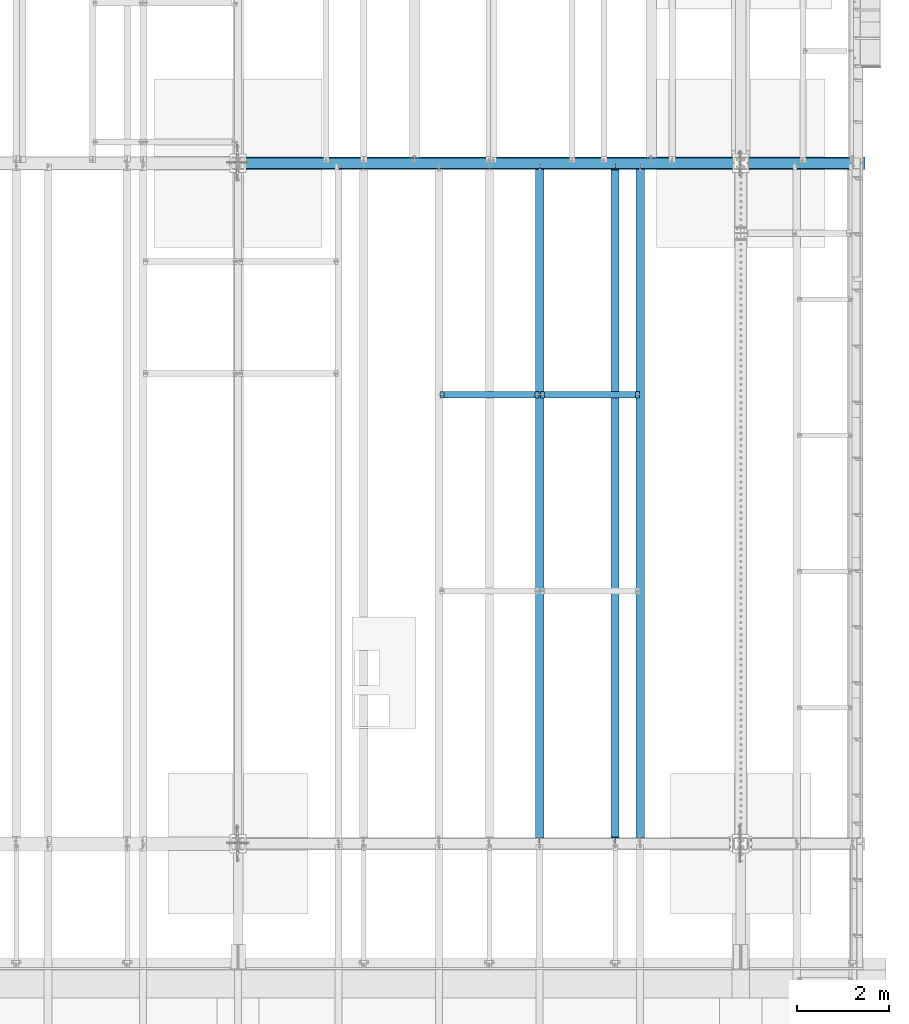
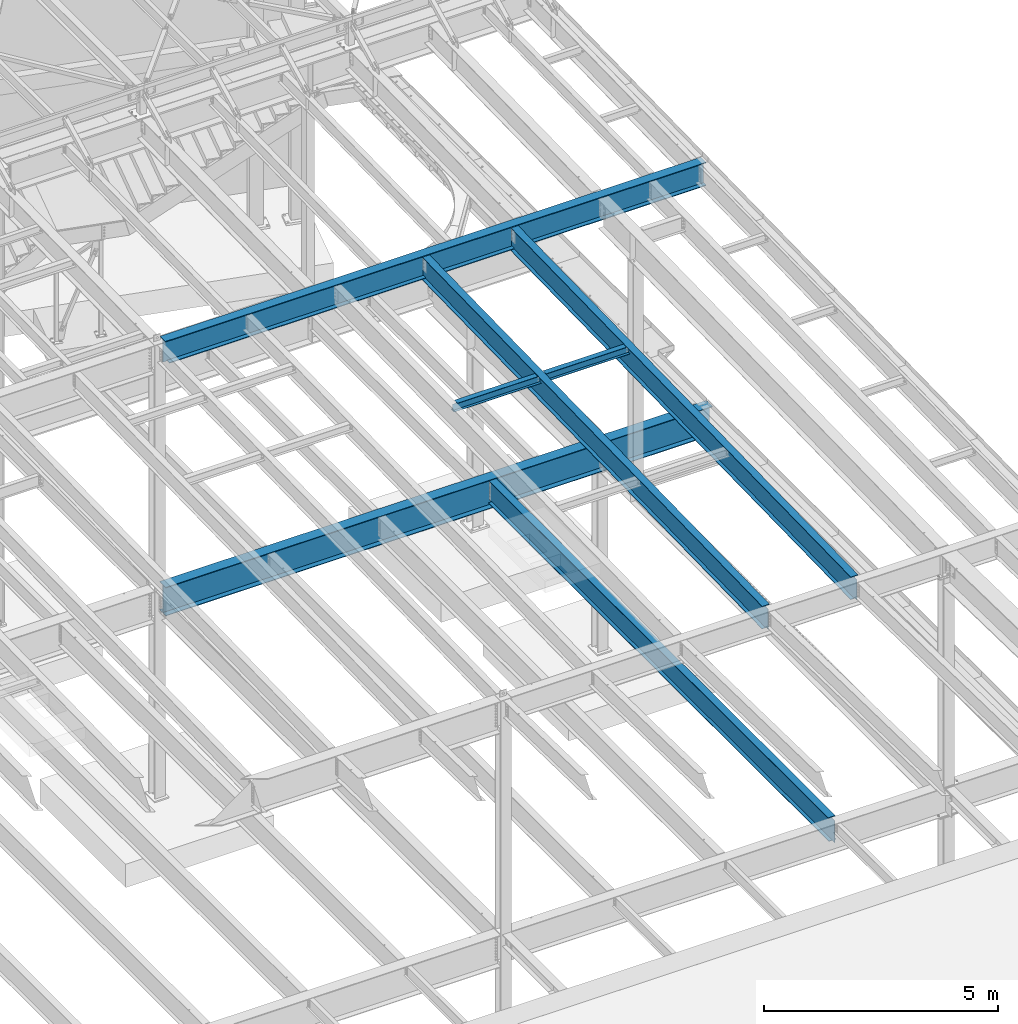
# One storey, part 1121 of 1763: 7 beams, 7 elements without a shape of their own.
"""IFC2X3 building model written with IfcOpenShell, lengths in millimetres."""

from ifc_helpers import new_model, si_unit, frame, origin_with_axes, place, context, subcontext, project, spatial, faceted_brep, material, type_object, element, aggregate, save


model = new_model("IFC2X3")

# Units and contexts
model_context = context("Model", 3, precision=1e-05, world=origin_with_axes())
body_context = subcontext(model_context, "Body", "Model", "MODEL_VIEW")
ifc_project = project(units=[si_unit("LENGTHUNIT", "METRE", prefix="MILLI"), si_unit("AREAUNIT", "SQUARE_METRE"), si_unit("VOLUMEUNIT", "CUBIC_METRE"), si_unit("MASSUNIT", "GRAM", prefix="KILO"), si_unit("TIMEUNIT", "SECOND"), si_unit("PLANEANGLEUNIT", "RADIAN"), si_unit("SOLIDANGLEUNIT", "STERADIAN"), si_unit("THERMODYNAMICTEMPERATUREUNIT", "DEGREE_CELSIUS"), si_unit("LUMINOUSINTENSITYUNIT", "LUMEN")], contexts=[model_context])

# Site, building, storey
site_placement = place(None, origin_with_axes())
site = spatial("IfcSite", under=ifc_project, at=site_placement, CompositionType="ELEMENT")
building_placement = place(site_placement, origin_with_axes())
building = spatial("IfcBuilding", under=site, at=building_placement, Name="Undefined", CompositionType="ELEMENT")
storey_placement = place(building_placement, origin_with_axes())
storey = spatial("IfcBuildingStorey", under=building, at=storey_placement, Name="Undefined", CompositionType="ELEMENT", Elevation=0.0)

# Assembly, beam
assembly_1_placement = place(storey_placement, origin_with_axes())
assembly_1 = element("IfcElementAssembly", 1, at=assembly_1_placement, inside=storey, Name="BEAM", AssemblyPlace="NOTDEFINED", PredefinedType="RIGID_FRAME")
ifc_material = material(Name="STEEL/A992")
beam_type_1 = type_object("IfcBeamType", Name="W8X18", PredefinedType="NOTDEFINED")
beam_1_placement = place(assembly_1_placement, frame((-28396.6372736984, 39776.4, 11388.9111170495), z_axis=(0.0, 0.0, 1.0), x_axis=(1.0, 0.0, 0.0)))
beam_1 = element("IfcBeam", 2, at=beam_1_placement, type_object=beam_type_1, material=ifc_material, Name="BEAM", ObjectType="W8X18", context=body_context, shape_type="Brep", body=[
    faceted_brep([(2088.10724382306, -3.17500000000018, 68.5472454972532), (2088.10724382306, 3.17500000000018, 68.5472454972532), (2087.24625903135, 3.17500000000291, 69.8358002989517), (2087.24625903135, -3.17500000000291, 69.8358002989517), (2092.22742029121, -3.17500000000018, 65.7942315967757), (2092.22742029121, 3.17500000000018, 65.7942315967757), (2097.08749980926, -3.17500000000018, 64.8275016741882), (2097.08749980926, 3.17500000000018, 64.8275016741882), (2166.93749999999, -3.17500000000018, 64.8275016741882), (2166.93749999999, 3.17500000000018, 64.8275016741882), (2086.51974687482, -3.17500000000291, 70.3212402021363), (2086.51974687482, 3.17500000000291, 70.3212402021363), (2083.76673297434, 3.17500000000291, 74.44141667029), (2083.76673297434, -3.17500000000291, 74.44141667029), (2082.80000305175, 3.17500000000291, 79.3014961883364), (2082.80000305175, -3.17500000000291, 79.3014961883364), (2082.80000305175, 66.6750000000002, 95.25), (2082.80000305175, 3.17500000000018, 95.25), (101.599996948244, 3.17500000000018, 95.25), (101.599996948244, 66.6750000000002, 95.25), (2082.80000305175, -66.6750000000002, 95.25), (2082.80000305175, -66.6750000000002, 103.1875), (101.599996948244, -66.6750000000002, 103.1875), (101.599996948244, -66.6750000000002, 95.25), (2082.80000305175, 66.6750000000002, 103.1875), (101.599996948244, 66.6750000000002, 103.1875), (2082.80000305175, -3.17500000000018, 95.25), (101.599996948244, -3.17500000000018, 95.25), (101.599996948236, 3.17499999999927, 79.301496189446), (101.599996948236, -3.17499999999927, 79.301496189446), (100.633267025652, 3.17499999999927, 74.4414166713996), (100.633267025652, -3.17499999999927, 74.4414166713996), (97.8802531251713, 3.17499999999927, 70.3212402032459), (97.8802531251713, -3.17499999999927, 70.3212402032459), (97.153740969894, 3.17499999999927, 69.8358003008998), (97.153740969894, -3.17499999999927, 69.8358003008998), (96.2927561769247, 3.17500000000018, 68.5472454911378), (96.2927561769247, -3.17500000000018, 68.5472454911378), (92.1725797087711, 3.17500000000018, 65.7942315906603), (92.1725797087711, -3.17500000000018, 65.7942315906603), (87.3125001907247, 3.17500000000018, 64.8275016680727), (87.3125001907247, -3.17500000000018, 64.8275016680727), (17.4624999999905, 3.17500000000018, 64.8275016680727), (17.4624999999905, -3.17500000000018, 64.8275016680727), (17.4624999999905, 3.17500000000018, -95.25), (17.4624999999905, 66.6750000000002, -95.25), (17.4624999999905, 66.6750000000002, -103.1875), (17.4624999999905, -66.6750000000002, -103.1875), (17.4624999999905, -66.6750000000002, -95.25), (17.4624999999905, -3.17500000000018, -95.25), (2166.93749999999, 3.17500000000018, -95.25), (2166.93749999999, 66.6750000000002, -95.25), (2166.93749999999, 66.6750000000002, -103.1875), (2166.93749999999, -66.6750000000002, -103.1875), (2166.93749999999, -66.6750000000002, -95.25), (2166.93749999999, -3.17500000000018, -95.25)], [[[0, 1, 2, 3]], [[4, 5, 1, 0]], [[6, 7, 5, 4]], [[8, 9, 7, 6]], [[10, 11, 12, 13]], [[13, 12, 14, 15]], [[16, 17, 18, 19]], [[20, 21, 22, 23]], [[21, 24, 25, 22]], [[24, 16, 19, 25]], [[21, 20, 26, 15, 14, 17, 16, 24]], [[26, 20, 23, 27]], [[22, 25, 19, 18, 28, 29, 27, 23]], [[29, 28, 30, 31]], [[31, 30, 32, 33]], [[33, 32, 34, 35]], [[35, 34, 36, 37]], [[37, 36, 38, 39]], [[39, 38, 40, 41]], [[41, 40, 42, 43]], [[44, 45, 46, 47, 48, 49, 43, 42]], [[45, 44, 50, 51]], [[46, 45, 51, 52]], [[47, 46, 52, 53]], [[48, 47, 53, 54]], [[49, 48, 54, 55]], [[4, 0, 3, 10, 13, 15, 26, 27, 29, 31, 33, 35, 37, 39, 41, 43, 49, 55, 8, 6]], [[11, 10, 3, 2]], [[50, 44, 42, 40, 38, 36, 34, 32, 30, 28, 18, 17, 14, 12, 11, 2, 1, 5, 7, 9]], [[55, 54, 53, 52, 51, 50, 9, 8]]]),
])
aggregate(assembly_1, [beam_1])

assembly_2_placement = place(storey_placement, origin_with_axes())
assembly_2 = element("IfcElementAssembly", 3, at=assembly_2_placement, inside=storey, Name="BEAM", AssemblyPlace="NOTDEFINED", PredefinedType="RIGID_FRAME")
beam_2_placement = place(assembly_2_placement, frame((-30581.0372736984, 39776.4, 11388.9111170495), z_axis=(0.0, 0.0, 1.0), x_axis=(1.0, 0.0, 0.0)))
beam_2 = element("IfcBeam", 4, at=beam_2_placement, type_object=beam_type_1, material=ifc_material, Name="BEAM", ObjectType="W8X18", context=body_context, shape_type="Brep", body=[
    faceted_brep([(2088.10724382306, -3.17500000000018, 68.5472454972532), (2088.10724382306, 3.17500000000018, 68.5472454972532), (2087.24625903135, 3.17500000000291, 69.8358002989517), (2087.24625903135, -3.17500000000291, 69.8358002989517), (2092.22742029121, -3.17500000000018, 65.7942315967757), (2092.22742029121, 3.17500000000018, 65.7942315967757), (2097.08749980926, -3.17500000000018, 64.8275016741882), (2097.08749980926, 3.17500000000018, 64.8275016741882), (2166.93749999999, -3.17500000000018, 64.8275016741882), (2166.93749999999, 3.17500000000018, 64.8275016741882), (2086.51974687482, -3.17500000000291, 70.3212402021363), (2086.51974687482, 3.17500000000291, 70.3212402021363), (2083.76673297434, 3.17500000000291, 74.44141667029), (2083.76673297434, -3.17500000000291, 74.44141667029), (2082.80000305175, 3.17500000000291, 79.3014961883364), (2082.80000305175, -3.17500000000291, 79.3014961883364), (2082.80000305175, 66.6750000000002, 95.25), (2082.80000305175, 3.17500000000018, 95.25), (101.599996948244, 3.17500000000018, 95.25), (101.599996948244, 66.6750000000002, 95.25), (2082.80000305175, -66.6750000000002, 95.25), (2082.80000305175, -66.6750000000002, 103.1875), (101.599996948244, -66.6750000000002, 103.1875), (101.599996948244, -66.6750000000002, 95.25), (2082.80000305175, 66.6750000000002, 103.1875), (101.599996948244, 66.6750000000002, 103.1875), (2082.80000305175, -3.17500000000018, 95.25), (101.599996948244, -3.17500000000018, 95.25), (101.599996948236, 3.17499999999927, 79.301496189446), (101.599996948236, -3.17499999999927, 79.301496189446), (100.633267025652, 3.17499999999927, 74.4414166713996), (100.633267025652, -3.17499999999927, 74.4414166713996), (97.8802531251713, 3.17499999999927, 70.3212402032459), (97.8802531251713, -3.17499999999927, 70.3212402032459), (97.153740969894, 3.17499999999927, 69.8358003008998), (97.153740969894, -3.17499999999927, 69.8358003008998), (96.2927561769247, 3.17500000000018, 68.5472454911378), (96.2927561769247, -3.17500000000018, 68.5472454911378), (92.1725797087711, 3.17500000000018, 65.7942315906603), (92.1725797087711, -3.17500000000018, 65.7942315906603), (87.3125001907247, 3.17500000000018, 64.8275016680727), (87.3125001907247, -3.17500000000018, 64.8275016680727), (17.4624999999905, 3.17500000000018, 64.8275016680727), (17.4624999999905, -3.17500000000018, 64.8275016680727), (17.4624999999905, 3.17500000000018, -95.25), (17.4624999999905, 66.6750000000002, -95.25), (17.4624999999905, 66.6750000000002, -103.1875), (17.4624999999905, -66.6750000000002, -103.1875), (17.4624999999905, -66.6750000000002, -95.25), (17.4624999999905, -3.17500000000018, -95.25), (2166.93749999999, 3.17500000000018, -95.25), (2166.93749999999, 66.6750000000002, -95.25), (2166.93749999999, 66.6750000000002, -103.1875), (2166.93749999999, -66.6750000000002, -103.1875), (2166.93749999999, -66.6750000000002, -95.25), (2166.93749999999, -3.17500000000018, -95.25)], [[[0, 1, 2, 3]], [[4, 5, 1, 0]], [[6, 7, 5, 4]], [[8, 9, 7, 6]], [[10, 11, 12, 13]], [[13, 12, 14, 15]], [[16, 17, 18, 19]], [[20, 21, 22, 23]], [[21, 24, 25, 22]], [[24, 16, 19, 25]], [[21, 20, 26, 15, 14, 17, 16, 24]], [[26, 20, 23, 27]], [[22, 25, 19, 18, 28, 29, 27, 23]], [[29, 28, 30, 31]], [[31, 30, 32, 33]], [[33, 32, 34, 35]], [[35, 34, 36, 37]], [[37, 36, 38, 39]], [[39, 38, 40, 41]], [[41, 40, 42, 43]], [[44, 45, 46, 47, 48, 49, 43, 42]], [[45, 44, 50, 51]], [[46, 45, 51, 52]], [[47, 46, 52, 53]], [[48, 47, 53, 54]], [[49, 48, 54, 55]], [[4, 0, 3, 10, 13, 15, 26, 27, 29, 31, 33, 35, 37, 39, 41, 43, 49, 55, 8, 6]], [[11, 10, 3, 2]], [[50, 44, 42, 40, 38, 36, 34, 32, 30, 28, 18, 17, 14, 12, 11, 2, 1, 5, 7, 9]], [[55, 54, 53, 52, 51, 50, 9, 8]]]),
])
aggregate(assembly_2, [beam_2])

assembly_3_placement = place(storey_placement, origin_with_axes())
assembly_3 = element("IfcElementAssembly", 5, at=assembly_3_placement, inside=storey, Name="BEAM", AssemblyPlace="NOTDEFINED", PredefinedType="RIGID_FRAME")
beam_type_2 = type_object("IfcBeamType", Name="W24X55", PredefinedType="NOTDEFINED")
beam_3_placement = place(assembly_3_placement, frame((-26212.2372736984, 30029.0063442244, 10990.3266966851), z_axis=(0.0, -0.0206852279954837, 0.999786037781472), x_axis=(0.0, 0.999786037781472, 0.0206852279954825)))
beam_3 = element("IfcBeam", 6, at=beam_3_placement, type_object=beam_type_2, material=ifc_material, Name="BEAM", ObjectType="W24X55", context=body_context, shape_type="Brep", body=[
    faceted_brep([(14647.1958080934, -4.76250000000073, -287.337500002572), (14647.1958080934, -88.9000000000015, -287.337500002572), (14647.1958080934, -88.9000000000015, -300.03750000256), (14647.1958080934, 88.9000000000015, -300.03750000256), (14647.1958080934, 88.9000000000015, -287.337500002572), (14647.1958080934, 4.76250000000073, -287.337500002572), (14647.1958080934, 4.76250000000073, -274.897499864639), (14647.1958080934, -4.76250000000073, -274.897499864639), (14648.162538016, 4.76250000000073, -270.037420346602), (14648.162538016, -4.76250000000073, -270.037420346602), (14650.9155519165, 4.76250000000073, -265.917243878457), (14650.9155519165, -4.76250000000073, -265.917243878457), (14655.0357283846, 4.76250000000073, -263.164229977987), (14655.0357283846, -4.76250000000073, -263.164229977987), (14659.8958079027, 4.76250000000073, -262.197500055401), (14659.8958079027, -4.76250000000073, -262.197500055401), (14756.0710323529, -4.76250000000073, -262.197500055443), (14756.0710323529, 4.76250000000073, -262.197500055443), (14647.1958080935, 88.9000000000015, 287.337499996996), (14647.1958080935, 4.76250000000073, 287.337499996996), (126.352484696479, 4.76250000000073, 287.337499999761), (126.352484696479, 88.9000000000015, 287.337499999761), (126.35248469637, -4.76250000000073, -274.897499808445), (126.35248469637, 4.76250000000073, -274.897499808445), (126.35248469637, 4.76250000000073, -287.337499999807), (126.35248469637, 88.9000000000015, -287.337499999807), (126.352484696366, 88.9000000000015, -300.037499999797), (126.352484696366, -88.9000000000015, -300.037499999797), (126.35248469637, -88.9000000000015, -287.337499999807), (126.35248469637, -4.76250000000073, -287.337499999807), (125.385754773786, -4.76250000000073, -270.03742029041), (125.385754773786, 4.76250000000073, -270.03742029041), (122.632740873316, -4.76250000000073, -265.917243822267), (122.632740873316, 4.76250000000073, -265.917243822267), (118.512564405166, -4.76250000000073, -263.164229921793), (118.512564405166, 4.76250000000073, -263.164229921793), (113.652484887134, -4.76250000000073, -262.197499999205), (113.652484887134, 4.76250000000073, -262.197499999205), (6.62770893273409, -4.76250000000073, -262.197499999185), (6.62770893273409, 4.76250000000073, -262.197499999185), (17.4665018757441, -4.76250000000073, 261.677501677954), (17.4665018757441, 4.76250000000073, 261.677501677954), (113.652484887236, -4.76250000000073, 261.677501677934), (113.652484887236, 4.76250000000073, 261.677501677934), (118.512564405268, -4.76250000000073, 262.64423160052), (118.512564405268, 4.76250000000073, 262.64423160052), (122.632740873414, -4.76250000000073, 265.39724550099), (122.632740873414, 4.76250000000073, 265.39724550099), (125.385754773884, -4.76250000000073, 269.517421969134), (125.385754773884, 4.76250000000073, 269.517421969134), (126.352484696472, -4.76250000000073, 274.377501487168), (126.352484696472, 4.76250000000073, 274.377501487168), (14647.1958080935, -88.9000000000015, 300.037499996986), (14647.1958080935, 88.9000000000015, 300.037499996986), (126.352484696483, 88.9000000000015, 300.037499999753), (126.352484696483, -88.9000000000015, 300.037499999753), (14647.1958080935, -88.9000000000015, 287.337499996996), (126.352484696479, -88.9000000000015, 287.337499999761), (14647.1958080935, -4.76250000000073, 287.337499996996), (126.352484696479, -4.76250000000073, 287.337499999761), (14647.1958080935, -4.76250000000073, 274.377501430976), (14647.1958080935, 4.76250000000073, 274.377501430976), (14648.1625380161, -4.76250000000073, 269.517421912944), (14648.1625380161, 4.76250000000073, 269.517421912944), (14650.9155519166, -4.76250000000073, 265.397245444798), (14650.9155519166, 4.76250000000073, 265.397245444798), (14655.0357283847, -4.76250000000073, 262.644231544326), (14655.0357283847, 4.76250000000073, 262.644231544326), (14659.8958079028, -4.76250000000073, 261.677501621738), (14659.8958079028, 4.76250000000073, 261.677501621738), (14766.9098252959, -4.76250000000073, 261.677501621718), (14766.9098252959, 4.76250000000073, 261.677501621718)], [[[0, 1, 2, 3, 4, 5, 6, 7]], [[7, 6, 8, 9]], [[9, 8, 10, 11]], [[11, 10, 12, 13]], [[13, 12, 14, 15]], [[16, 15, 14, 17]], [[18, 19, 20, 21]], [[22, 23, 24, 25, 26, 27, 28, 29]], [[30, 31, 23, 22]], [[32, 33, 31, 30]], [[34, 35, 33, 32]], [[36, 37, 35, 34]], [[38, 39, 37, 36]], [[40, 41, 39, 38]], [[42, 43, 41, 40]], [[44, 45, 43, 42]], [[46, 47, 45, 44]], [[48, 49, 47, 46]], [[50, 51, 49, 48]], [[52, 53, 54, 55]], [[56, 52, 55, 57]], [[58, 56, 57, 59]], [[55, 54, 21, 20, 51, 50, 59, 57]], [[53, 18, 21, 54]], [[52, 56, 58, 60, 61, 19, 18, 53]], [[62, 63, 61, 60]], [[64, 65, 63, 62]], [[66, 67, 65, 64]], [[68, 69, 67, 66]], [[70, 71, 69, 68]], [[71, 70, 16, 17]], [[12, 10, 8, 6, 5, 24, 23, 31, 33, 35, 37, 39, 41, 43, 45, 47, 49, 51, 20, 19, 61, 63, 65, 67, 69, 71, 17, 14]], [[25, 24, 5, 4]], [[26, 25, 4, 3]], [[27, 26, 3, 2]], [[28, 27, 2, 1]], [[29, 28, 1, 0]], [[70, 68, 66, 64, 62, 60, 58, 59, 50, 48, 46, 44, 42, 40, 38, 36, 34, 32, 30, 22, 29, 0, 7, 9, 11, 13, 15, 16]]]),
])
aggregate(assembly_3, [beam_3])

assembly_4_placement = place(storey_placement, origin_with_axes())
assembly_4 = element("IfcElementAssembly", 7, at=assembly_4_placement, inside=storey, Name="BEAM", AssemblyPlace="NOTDEFINED", PredefinedType="RIGID_FRAME")
beam_4_placement = place(assembly_4_placement, frame((-28396.6372736984, 30029.0063442244, 10990.3266966851), z_axis=(0.0, -0.0206852279954837, 0.999786037781472), x_axis=(0.0, 0.999786037781472, 0.0206852279954825)))
beam_4 = element("IfcBeam", 8, at=beam_4_placement, type_object=beam_type_2, material=ifc_material, Name="BEAM", ObjectType="W24X55", context=body_context, shape_type="Brep", body=[
    faceted_brep([(14647.1958080934, -4.76250000000073, -287.337500002572), (14647.1958080934, -88.9000000000015, -287.337500002572), (14647.1958080934, -88.9000000000015, -300.03750000256), (14647.1958080934, 88.9000000000015, -300.03750000256), (14647.1958080934, 88.9000000000015, -287.337500002572), (14647.1958080934, 4.76250000000073, -287.337500002572), (14647.1958080934, 4.76250000000073, -274.897499864639), (14647.1958080934, -4.76250000000073, -274.897499864639), (14648.162538016, 4.76250000000073, -270.037420346602), (14648.162538016, -4.76250000000073, -270.037420346602), (14650.9155519165, 4.76250000000073, -265.917243878457), (14650.9155519165, -4.76250000000073, -265.917243878457), (14655.0357283846, 4.76250000000073, -263.164229977987), (14655.0357283846, -4.76250000000073, -263.164229977987), (14659.8958079027, 4.76250000000073, -262.197500055401), (14659.8958079027, -4.76250000000073, -262.197500055401), (14756.0710323529, -4.76250000000073, -262.197500055443), (14756.0710323529, 4.76250000000073, -262.197500055443), (14647.1958080935, 88.9000000000015, 287.337499996996), (14647.1958080935, 4.76250000000073, 287.337499996996), (126.352484696479, 4.76250000000073, 287.337499999761), (126.352484696479, 88.9000000000015, 287.337499999761), (126.35248469637, -4.76250000000073, -274.897499808445), (126.35248469637, 4.76250000000073, -274.897499808445), (126.35248469637, 4.76250000000073, -287.337499999807), (126.35248469637, 88.9000000000015, -287.337499999807), (126.352484696366, 88.9000000000015, -300.037499999797), (126.352484696366, -88.9000000000015, -300.037499999797), (126.35248469637, -88.9000000000015, -287.337499999807), (126.35248469637, -4.76250000000073, -287.337499999807), (125.385754773786, -4.76250000000073, -270.03742029041), (125.385754773786, 4.76250000000073, -270.03742029041), (122.632740873316, -4.76250000000073, -265.917243822267), (122.632740873316, 4.76250000000073, -265.917243822267), (118.512564405166, -4.76250000000073, -263.164229921793), (118.512564405166, 4.76250000000073, -263.164229921793), (113.652484887134, -4.76250000000073, -262.197499999205), (113.652484887134, 4.76250000000073, -262.197499999205), (6.62770893273409, -4.76250000000073, -262.197499999185), (6.62770893273409, 4.76250000000073, -262.197499999185), (17.4665018757441, -4.76250000000073, 261.677501677954), (17.4665018757441, 4.76250000000073, 261.677501677954), (113.652484887236, -4.76250000000073, 261.677501677934), (113.652484887236, 4.76250000000073, 261.677501677934), (118.512564405268, -4.76250000000073, 262.64423160052), (118.512564405268, 4.76250000000073, 262.64423160052), (122.632740873414, -4.76250000000073, 265.39724550099), (122.632740873414, 4.76250000000073, 265.39724550099), (125.385754773884, -4.76250000000073, 269.517421969134), (125.385754773884, 4.76250000000073, 269.517421969134), (126.352484696472, -4.76250000000073, 274.377501487168), (126.352484696472, 4.76250000000073, 274.377501487168), (14647.1958080935, -88.9000000000015, 300.037499996986), (14647.1958080935, 88.9000000000015, 300.037499996986), (126.352484696483, 88.9000000000015, 300.037499999753), (126.352484696483, -88.9000000000015, 300.037499999753), (14647.1958080935, -88.9000000000015, 287.337499996996), (126.352484696479, -88.9000000000015, 287.337499999761), (14647.1958080935, -4.76250000000073, 287.337499996996), (126.352484696479, -4.76250000000073, 287.337499999761), (14647.1958080935, -4.76250000000073, 274.377501430976), (14647.1958080935, 4.76250000000073, 274.377501430976), (14648.1625380161, -4.76250000000073, 269.517421912944), (14648.1625380161, 4.76250000000073, 269.517421912944), (14650.9155519166, -4.76250000000073, 265.397245444798), (14650.9155519166, 4.76250000000073, 265.397245444798), (14655.0357283847, -4.76250000000073, 262.644231544326), (14655.0357283847, 4.76250000000073, 262.644231544326), (14659.8958079028, -4.76250000000073, 261.677501621738), (14659.8958079028, 4.76250000000073, 261.677501621738), (14766.9098252959, -4.76250000000073, 261.677501621718), (14766.9098252959, 4.76250000000073, 261.677501621718)], [[[0, 1, 2, 3, 4, 5, 6, 7]], [[7, 6, 8, 9]], [[9, 8, 10, 11]], [[11, 10, 12, 13]], [[13, 12, 14, 15]], [[16, 15, 14, 17]], [[18, 19, 20, 21]], [[22, 23, 24, 25, 26, 27, 28, 29]], [[30, 31, 23, 22]], [[32, 33, 31, 30]], [[34, 35, 33, 32]], [[36, 37, 35, 34]], [[38, 39, 37, 36]], [[40, 41, 39, 38]], [[42, 43, 41, 40]], [[44, 45, 43, 42]], [[46, 47, 45, 44]], [[48, 49, 47, 46]], [[50, 51, 49, 48]], [[52, 53, 54, 55]], [[56, 52, 55, 57]], [[58, 56, 57, 59]], [[55, 54, 21, 20, 51, 50, 59, 57]], [[53, 18, 21, 54]], [[52, 56, 58, 60, 61, 19, 18, 53]], [[62, 63, 61, 60]], [[64, 65, 63, 62]], [[66, 67, 65, 64]], [[68, 69, 67, 66]], [[70, 71, 69, 68]], [[71, 70, 16, 17]], [[12, 10, 8, 6, 5, 24, 23, 31, 33, 35, 37, 39, 41, 43, 45, 47, 49, 51, 20, 19, 61, 63, 65, 67, 69, 71, 17, 14]], [[25, 24, 5, 4]], [[26, 25, 4, 3]], [[27, 26, 3, 2]], [[28, 27, 2, 1]], [[29, 28, 1, 0]], [[70, 68, 66, 64, 62, 60, 58, 59, 50, 48, 46, 44, 42, 40, 38, 36, 34, 32, 30, 22, 29, 0, 7, 9, 11, 13, 15, 16]]]),
])
aggregate(assembly_4, [beam_4])

assembly_5_placement = place(storey_placement, origin_with_axes())
assembly_5 = element("IfcElementAssembly", 9, at=assembly_5_placement, inside=storey, Name="BEAM", AssemblyPlace="NOTDEFINED", PredefinedType="RIGID_FRAME")
beam_type_3 = type_object("IfcBeamType", Name="W24X76", PredefinedType="NOTDEFINED")
beam_5_placement = place(assembly_5_placement, frame((-34949.8372736984, 44805.5999999732, 11291.9463409688), z_axis=(0.0, 0.0, 1.0), x_axis=(1.0, 0.0, 0.0)))
beam_5 = element("IfcBeam", 10, at=beam_5_placement, type_object=beam_type_3, material=ifc_material, Name="BEAM", ObjectType="W24X76", context=body_context, shape_type="Brep", body=[
    faceted_brep([(141.287499999999, -5.55625000000146, -285.75), (141.287499999999, -5.55616680142703, -303.2125), (242.887547043421, -5.55606845251168, -303.2125), (242.887547043807, -5.55625000000146, -285.75), (242.887652307618, -114.300000000003, -285.75), (242.887652307618, -114.300000000003, -303.2125), (13474.7046875, 5.55625000000146, -285.75), (13474.7046875, 114.300000000003, -285.75), (242.887504835548, 114.300000000003, -285.75), (242.887610099882, 5.55606844258728, -285.750000003743), (141.287499999999, -114.299999999999, 285.75), (141.287499999999, -5.55625000000146, 285.75), (13474.7046875, -5.55625000000146, 285.75), (13474.7046875, -114.300000000003, 285.75), (141.287499999999, -114.299999999999, 303.2125), (13474.7046875, -114.300000000003, 303.2125), (141.287499999999, 114.299999999999, 303.2125), (13474.7046875, 114.300000000003, 303.2125), (141.287499999999, 114.299999999999, 285.75), (13474.7046875, 114.300000000003, 285.75), (141.287499999999, 5.55625000000146, 285.75), (13474.7046875, 5.55625000000146, 285.75), (141.287499999999, 5.55625000000146, -285.75), (141.287499999999, 5.55625000000146, -277.814741971179), (13474.7046875, -114.300000000003, -303.2125), (13474.7046875, -114.300000000003, -285.75), (141.287499999999, 5.55633011798636, -303.2125), (242.887610099497, 5.55642846695991, -303.2125), (242.887504835548, 114.300000000003, -303.2125), (13474.7046875, 114.300000000003, -303.2125), (141.287499999999, -5.55625000000146, -277.814971159916), (13474.7046875, -5.55625000000146, -285.75)], [[[0, 1, 2, 3]], [[4, 3, 2, 5]], [[6, 7, 8, 9]], [[10, 11, 12, 13]], [[14, 10, 13, 15]], [[16, 14, 15, 17]], [[18, 16, 17, 19]], [[20, 18, 19, 21]], [[9, 22, 23, 20, 21, 6]], [[24, 25, 4, 5]], [[1, 26, 27, 28, 29, 24, 5, 2]], [[30, 11, 10, 14, 16, 18, 20, 23, 22, 26, 1, 0]], [[9, 27, 26, 22]], [[8, 28, 27, 9]], [[7, 29, 28, 8]], [[6, 21, 19, 17, 15, 13, 12, 31, 25, 24, 29, 7]], [[11, 30, 0, 3, 31, 12]], [[25, 31, 3, 4]]]),
])
aggregate(assembly_5, [beam_5])

assembly_6_placement = place(storey_placement, origin_with_axes())
assembly_6 = element("IfcElementAssembly", 11, at=assembly_6_placement, inside=storey, Name="BEAM", AssemblyPlace="NOTDEFINED", PredefinedType="RIGID_FRAME")
beam_type_4 = type_object("IfcBeamType", Name="W30X90", PredefinedType="NOTDEFINED")
beam_6_placement = place(assembly_6_placement, frame((-34949.8372736984, 44805.6, 4819.65), z_axis=(0.0, 0.0, 1.0), x_axis=(1.0, 0.0, 0.0)))
beam_6 = element("IfcBeam", 12, at=beam_6_placement, type_object=beam_type_4, material=ifc_material, Name="BEAM", ObjectType="W30X90", context=body_context, shape_type="Brep", body=[
    faceted_brep([(141.287500000006, 131.762500000001, -374.65), (141.287500000006, 131.762500000001, -358.775), (13620.75, 131.762499999997, -358.775), (13620.75, 131.762499999997, -374.65), (141.287500000006, 6.34999999999854, -358.775), (13620.75, 6.34999999999854, -358.775), (141.287500000006, 6.34999999999854, 358.775), (13620.75, 6.34999999999854, 358.775), (141.287500000006, 131.762500000001, 358.775), (13620.75, 131.762499999997, 358.775), (141.287500000006, 131.762500000001, 374.65), (13620.75, 131.762499999997, 374.65), (141.287500000006, -131.762500000001, 374.65), (13620.75, -131.762499999997, 374.65), (141.287500000006, -131.762500000001, 358.775), (13620.75, -131.762499999997, 358.775), (141.287500000006, -6.34999999999854, 358.775), (13620.75, -6.34999999999854, 358.775), (141.287500000006, -6.34999999999854, -358.775), (13620.75, -6.34999999999854, -358.775), (141.287500000006, -131.762500000001, -358.775), (13620.75, -131.762499999997, -358.775), (141.287500000006, -131.762500000001, -374.65), (13620.75, -131.762499999997, -374.65)], [[[0, 1, 2, 3]], [[1, 4, 5, 2]], [[4, 6, 7, 5]], [[6, 8, 9, 7]], [[8, 10, 11, 9]], [[10, 12, 13, 11]], [[12, 14, 15, 13]], [[14, 16, 17, 15]], [[16, 18, 19, 17]], [[18, 20, 21, 19]], [[20, 22, 23, 21]], [[22, 0, 3, 23]], [[5, 7, 9, 11, 13, 15, 17, 19, 21, 23, 3, 2]], [[22, 20, 18, 16, 14, 12, 10, 8, 6, 4, 1, 0]]]),
])
aggregate(assembly_6, [beam_6])

assembly_7_placement = place(storey_placement, origin_with_axes())
assembly_7 = element("IfcElementAssembly", 13, at=assembly_7_placement, inside=storey, Name="BEAM", AssemblyPlace="NOTDEFINED", PredefinedType="RIGID_FRAME")
beam_type_5 = type_object("IfcBeamType", Name="W24X62", PredefinedType="NOTDEFINED")
beam_7_placement = place(assembly_7_placement, frame((-26758.3372736984, 30022.8, 4892.675), z_axis=(0.0, 0.0, 1.0), x_axis=(0.0, 1.0, 0.0)))
beam_7 = element("IfcBeam", 14, at=beam_7_placement, type_object=beam_type_5, material=ifc_material, Name="BEAM", ObjectType="W24X62", context=body_context, shape_type="Brep", body=[
    faceted_brep([(19.0500000000029, -5.85639903280753, -287.3375), (19.0500000000029, -5.85613127077522, -301.625), (120.650010332869, -5.85611918055292, -301.625), (120.65001033292, -5.85638694259978, -287.3375), (120.650020215031, -88.9000000000015, -287.3375), (120.65002021494, -88.9000000000015, -301.625), (146.050000000003, -5.55625000000146, 282.315001487731), (146.050000000003, 5.55625000000146, 282.315001487731), (145.083270077415, 5.55625000000146, 277.454921969686), (145.083270077415, -5.55625000000146, 277.454921969686), (142.330256176938, 5.55625000000146, 273.334745501532), (142.330256176938, -5.55625000000146, 273.334745501532), (138.210079708784, 5.55625000000146, 270.581731601053), (138.210079708784, -5.55625000000146, 270.581731601053), (133.350000190738, 5.55625000000146, 269.615001678466), (133.350000190738, -5.55625000000146, 269.615001678466), (19.0500000000029, 5.55625000000146, 269.615001678466), (19.0500000000029, -5.55625000000146, 269.615001678466), (19.0500000000029, -5.55625000000146, -287.3375), (14763.75, -5.55625000000146, -287.3375), (14763.75, -5.55625000000146, 269.615001678466), (14649.4499998093, -5.55625000000146, 269.615001678466), (14644.5899202912, -5.55625000000146, 270.581731601053), (14640.4697438231, -5.55625000000146, 273.334745501532), (14637.7167299226, -5.55625000000146, 277.454921969686), (14636.75, -5.55625000000146, 282.315001487731), (14636.75, -5.55625000000146, 287.3375), (146.050000000003, -5.55625000000146, 287.3375), (14763.75, 5.55625000000146, 269.615001678466), (14649.4499998093, 5.55625000000146, 269.615001678466), (14644.5899202912, 5.55625000000146, 270.581731601053), (14640.4697438231, 5.55625000000146, 273.334745501532), (14637.7167299226, 5.55625000000146, 277.454921969686), (14636.75, 5.55625000000146, 282.315001487731), (14636.75, -88.9000000000015, 301.625), (14636.75, -88.9000000000015, 287.3375), (14636.75, 5.55625000000146, 287.3375), (14636.75, 88.9000000000015, 287.3375), (14636.75, 88.9000000000015, 301.625), (146.050000000003, 5.55625000000146, 287.3375), (146.049999999999, 88.9000000000015, 287.3375), (146.050000000003, 88.9000000000015, 301.625), (146.050000000003, -88.9000000000015, 301.625), (146.049999999999, -88.9000000000015, 287.3375), (14763.75, 5.55625000000146, -287.3375), (19.0500000000029, 5.55625000000146, -287.3375), (14763.75, 5.85639903281481, -287.3375), (14662.1499896671, 5.85638694260706, -287.3375), (14662.1499797849, 88.9000000000015, -287.3375), (120.650000595357, 88.9000000000015, -287.3375), (120.650010477239, 5.85611915402842, -287.3375), (19.0500000000029, 5.85610706381703, -287.3375), (120.650010477188, 5.85638691607164, -301.625), (19.0500000000029, 5.85637482584934, -301.625), (120.650000595248, 88.9000000000015, -301.625), (14662.149979785, 88.9000000000015, -301.625), (14662.1499896671, 5.8561191805602, -301.625), (14763.75, 5.8561312707825, -301.625), (14763.75, -5.85610706381703, -287.3375), (14763.75, -5.85637482584934, -301.625), (14662.1499895228, -5.85611915402842, -287.3375), (14662.1499895228, -5.85638691607164, -301.625), (14662.1499994046, -88.9000000000015, -287.3375), (14662.1499994047, -88.9000000000015, -301.625)], [[[0, 1, 2, 3]], [[4, 3, 2, 5]], [[6, 7, 8, 9]], [[9, 8, 10, 11]], [[11, 10, 12, 13]], [[13, 12, 14, 15]], [[15, 14, 16, 17]], [[9, 11, 13, 15, 17, 18, 19, 20, 21, 22, 23, 24, 25, 26, 27, 6]], [[20, 28, 29, 21]], [[21, 29, 30, 22]], [[22, 30, 31, 23]], [[23, 31, 32, 24]], [[24, 32, 33, 25]], [[34, 35, 26, 25, 33, 36, 37, 38]], [[37, 36, 39, 40]], [[38, 37, 40, 41]], [[34, 38, 41, 42]], [[35, 34, 42, 43]], [[26, 35, 43, 27]], [[42, 41, 40, 39, 7, 6, 27, 43]], [[36, 33, 32, 31, 30, 29, 28, 44, 45, 16, 14, 12, 10, 8, 7, 39]], [[45, 44, 46, 47, 48, 49, 50, 51]], [[50, 52, 53, 51]], [[49, 54, 52, 50]], [[48, 55, 54, 49]], [[47, 56, 55, 48]], [[46, 57, 56, 47]], [[44, 28, 20, 19, 58, 59, 57, 46]], [[58, 60, 61, 59]], [[62, 63, 61, 60]], [[63, 62, 4, 5]], [[1, 53, 52, 54, 55, 56, 57, 59, 61, 63, 5, 2]], [[18, 17, 16, 45, 51, 53, 1, 0]], [[62, 60, 58, 19, 18, 0, 3, 4]]]),
])
aggregate(assembly_7, [beam_7])

save(model, "model.ifc")
